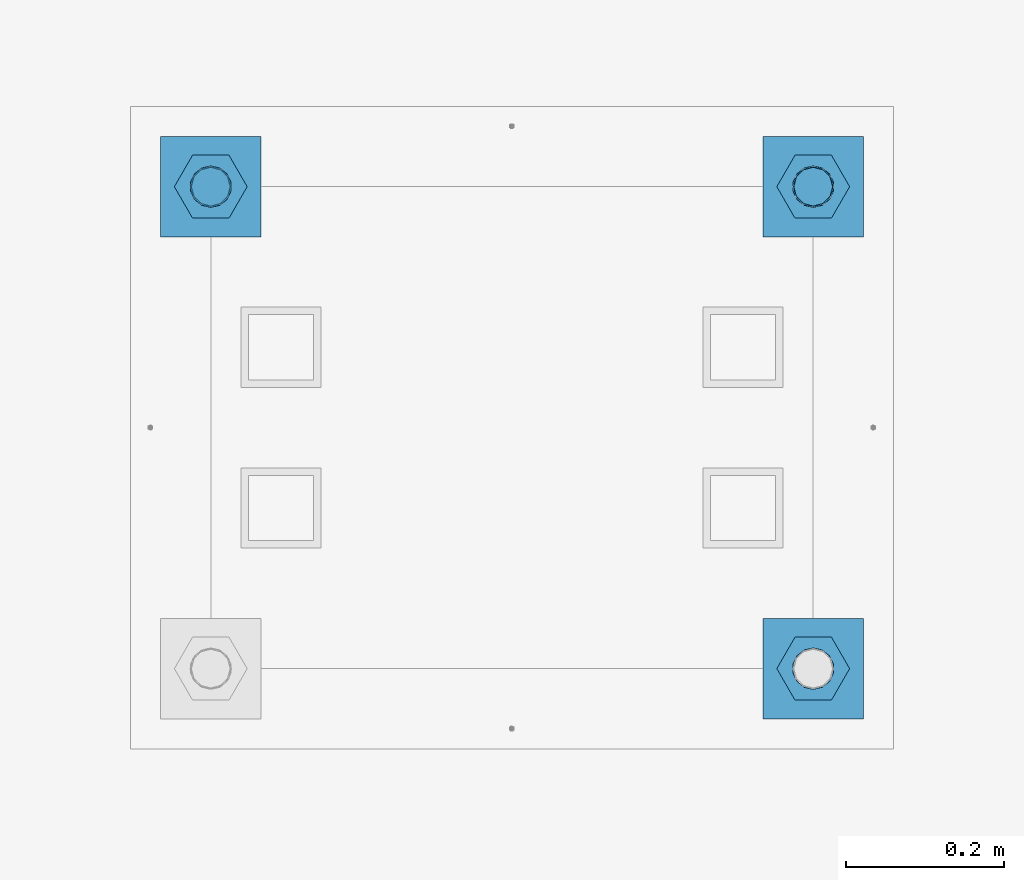
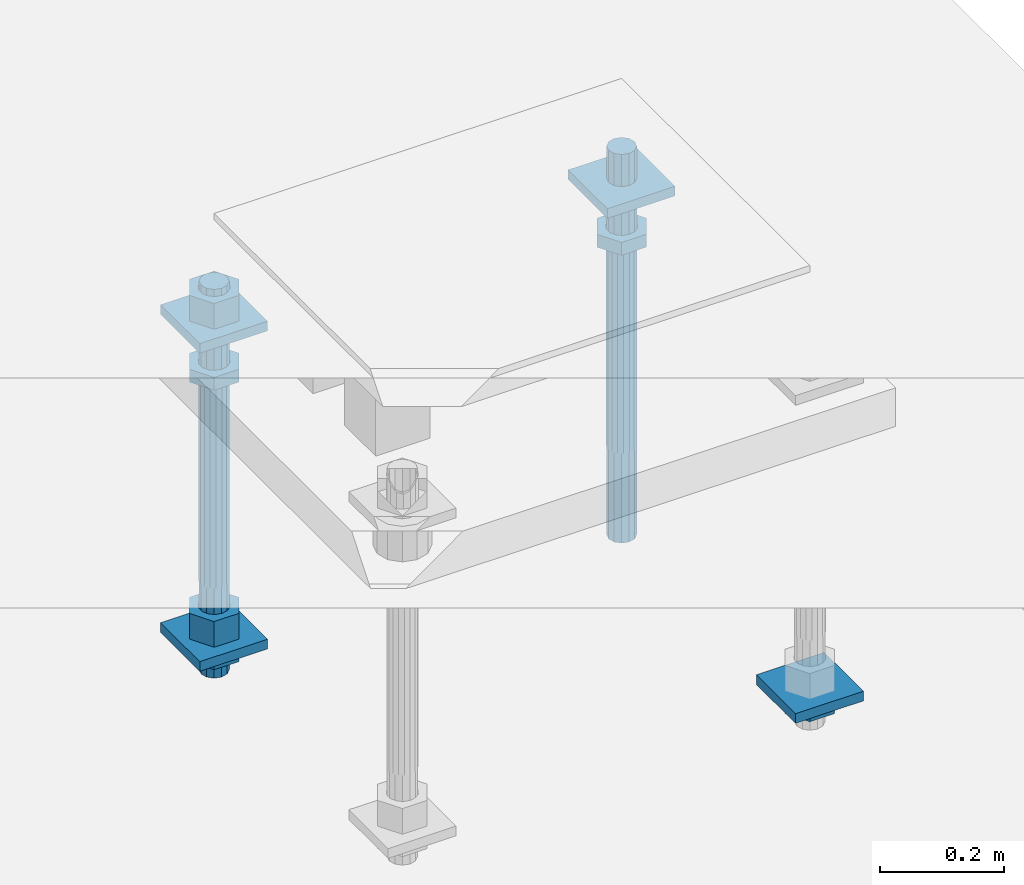
# One storey, part 2651 of 3843: 12 beams, 1 element without a shape of its own.
"""IFC2X3 building model written with IfcOpenShell, lengths in millimetres."""

from ifc_helpers import new_model, si_unit, frame, origin_with_axes, place, context, subcontext, project, spatial, faceted_brep, material, type_object, element, aggregate, save


model = new_model("IFC2X3")

# Units and contexts
model_context = context("Model", 3, precision=1e-05, world=origin_with_axes())
body_context = subcontext(model_context, "Body", "Model", "MODEL_VIEW")
ifc_project = project(units=[si_unit("LENGTHUNIT", "METRE", prefix="MILLI"), si_unit("AREAUNIT", "SQUARE_METRE"), si_unit("VOLUMEUNIT", "CUBIC_METRE"), si_unit("MASSUNIT", "GRAM", prefix="KILO"), si_unit("TIMEUNIT", "SECOND"), si_unit("PLANEANGLEUNIT", "RADIAN"), si_unit("SOLIDANGLEUNIT", "STERADIAN"), si_unit("THERMODYNAMICTEMPERATUREUNIT", "DEGREE_CELSIUS"), si_unit("LUMINOUSINTENSITYUNIT", "LUMEN")], contexts=[model_context])

# Site, building, storey
site_placement = place(None, origin_with_axes())
site = spatial("IfcSite", under=ifc_project, at=site_placement, CompositionType="ELEMENT")
building_placement = place(site_placement, origin_with_axes())
building = spatial("IfcBuilding", under=site, at=building_placement, Name="Undefined", CompositionType="ELEMENT")
storey_placement = place(building_placement, origin_with_axes())
storey = spatial("IfcBuildingStorey", under=building, at=storey_placement, Name="Undefined", CompositionType="ELEMENT", Elevation=0.0)

# Assembly, beams
assembly_placement = place(storey_placement, origin_with_axes())
assembly = element("IfcElementAssembly", 1, at=assembly_placement, inside=storey, Name="TEMPLATE", AssemblyPlace="NOTDEFINED", PredefinedType="RIGID_FRAME")
ifc_material_1 = material(Name="STEEL/A572-50")
beam_type_1 = type_object("IfcBeamType", PredefinedType="NOTDEFINED")
beam_1_placement = place(assembly_placement, frame((118465.6, 10744.2000015259, 29873.575), z_axis=(1.0, 0.0, 0.0), x_axis=(0.0, 1.0, 0.0)))
beam_1 = element("IfcBeam", 2, at=beam_1_placement, type_object=beam_type_1, material=ifc_material_1, Name="WASHER_PLATE", context=body_context, shape_type="Brep", body=[
    faceted_brep([(0.0, 9.52500000000146, -63.5), (0.0, 9.52500000000146, 63.5), (127.0, 9.52500000000146, 63.5), (127.0, 9.52500000000146, -63.5), (0.0, -9.52500000000146, 63.5), (127.0, -9.52500000000146, 63.5), (0.0, -9.52500000000146, -63.5), (127.0, -9.52500000000146, -63.5)], [[[0, 1, 2, 3]], [[1, 4, 5, 2]], [[4, 6, 7, 5]], [[6, 0, 3, 7]], [[5, 7, 3, 2]], [[6, 4, 1, 0]]]),
])
beam_2_placement = place(assembly_placement, frame((119227.6, 10744.2000015259, 29873.575), z_axis=(1.0, 0.0, 0.0), x_axis=(0.0, 1.0, 0.0)))
beam_2 = element("IfcBeam", 3, at=beam_2_placement, type_object=beam_type_1, material=ifc_material_1, Name="WASHER_PLATE", context=body_context, shape_type="Brep", body=[
    faceted_brep([(0.0, 9.52500000000146, -63.5), (0.0, 9.52500000000146, 63.5), (127.0, 9.52500000000146, 63.5), (127.0, 9.52500000000146, -63.5), (0.0, -9.52500000000146, 63.5), (127.0, -9.52500000000146, 63.5), (0.0, -9.52500000000146, -63.5), (127.0, -9.52500000000146, -63.5)], [[[0, 1, 2, 3]], [[1, 4, 5, 2]], [[4, 6, 7, 5]], [[6, 0, 3, 7]], [[5, 7, 3, 2]], [[6, 4, 1, 0]]]),
])
beam_3_placement = place(assembly_placement, frame((119227.6, 10134.6000015259, 29244.925), z_axis=(1.0, 0.0, 0.0), x_axis=(0.0, 1.0, 0.0)))
beam_3 = element("IfcBeam", 4, at=beam_3_placement, type_object=beam_type_1, material=ifc_material_1, Name="WASHER_PLATE", context=body_context, shape_type="Brep", body=[
    faceted_brep([(0.0, 9.52500000000146, -63.5), (0.0, 9.52500000000146, 63.5), (127.0, 9.52500000000146, 63.5), (127.0, 9.52500000000146, -63.5), (0.0, -9.52500000000146, 63.5), (127.0, -9.52500000000146, 63.5), (0.0, -9.52500000000146, -63.5), (127.0, -9.52500000000146, -63.5)], [[[0, 1, 2, 3]], [[1, 4, 5, 2]], [[4, 6, 7, 5]], [[6, 0, 3, 7]], [[5, 7, 3, 2]], [[6, 4, 1, 0]]]),
])
beam_4_placement = place(assembly_placement, frame((118465.6, 10744.2000015259, 29244.925), z_axis=(1.0, 0.0, 0.0), x_axis=(0.0, 1.0, 0.0)))
beam_4 = element("IfcBeam", 5, at=beam_4_placement, type_object=beam_type_1, material=ifc_material_1, Name="WASHER_PLATE", context=body_context, shape_type="Brep", body=[
    faceted_brep([(0.0, 9.52500000000146, -63.5), (0.0, 9.52500000000146, 63.5), (127.0, 9.52500000000146, 63.5), (127.0, 9.52500000000146, -63.5), (0.0, -9.52500000000146, 63.5), (127.0, -9.52500000000146, 63.5), (0.0, -9.52500000000146, -63.5), (127.0, -9.52500000000146, -63.5)], [[[0, 1, 2, 3]], [[1, 4, 5, 2]], [[4, 6, 7, 5]], [[6, 0, 3, 7]], [[5, 7, 3, 2]], [[6, 4, 1, 0]]]),
])
ifc_material_2 = material(Name="STEEL/A36")
beam_type_2 = type_object("IfcBeamType", Name="2_HALF_NUT", PredefinedType="NOTDEFINED")
beam_5_placement = place(assembly_placement, frame((119227.6, 10198.1000015259, 29235.4), z_axis=(0.0, 1.0, 0.0), x_axis=(0.0, 0.0, -1.0)))
beam_5 = element("IfcBeam", 6, at=beam_5_placement, type_object=beam_type_2, material=ifc_material_2, Name="NUT", ObjectType="2_HALF_NUT", context=body_context, shape_type="Brep", body=[
    faceted_brep([(0.0, -46.0369987487793, 0.0), (0.0, -23.0184993743896, -39.869213104248), (25.4000000000015, -23.0184993743896, -39.869213104248), (25.4000000000015, -46.0369987487793, 0.0), (0.0, 23.0184993743896, -39.869213104248), (25.4000000000015, 23.0184993743896, -39.869213104248), (0.0, 46.0369987487793, 0.0), (25.4000000000015, 46.0369987487793, 0.0), (0.0, 23.0184993743896, 39.869213104248), (25.4000000000015, 23.0184993743896, 39.869213104248), (0.0, -23.0184993743896, 39.869213104248), (25.4000000000015, -23.0184993743896, 39.869213104248), (0.0, 0.0, 26.1940002441406), (0.0, 11.3650617044477, 23.5999013092805), (25.4000000000015, 11.3650617044477, 23.5999013092805), (25.4000000000015, 0.0, 26.1940002441406), (0.0, 20.4791109456419, 16.3316083006721), (25.4000000000015, 20.4791109456419, 16.3316083006721), (0.0, 25.5370200498292, 5.82867859874386), (25.4000000000015, 25.5370200498292, 5.82867859874386), (0.0, 25.5370200498292, -5.82867859874386), (25.4000000000015, 25.5370200498292, -5.82867859874386), (0.0, 20.4791109456419, -16.3316083006721), (25.4000000000015, 20.4791109456419, -16.3316083006721), (0.0, 11.3650617044477, -23.5999013092805), (25.4000000000015, 11.3650617044477, -23.5999013092805), (0.0, 0.0, -26.1940002441406), (25.4000000000015, 0.0, -26.1940002441406), (0.0, -11.3650617044477, -23.5999013092805), (25.4000000000015, -11.3650617044477, -23.5999013092805), (0.0, -20.4791109456419, -16.3316083006721), (25.4000000000015, -20.4791109456419, -16.3316083006721), (0.0, -25.5370200498292, -5.82867859874386), (25.4000000000015, -25.5370200498292, -5.82867859874386), (0.0, -25.5370200498292, 5.82867859874386), (25.4000000000015, -25.5370200498292, 5.82867859874386), (0.0, -20.4791109456419, 16.3316083006721), (25.4000000000015, -20.4791109456419, 16.3316083006721), (0.0, -11.3650617044477, 23.5999013092805), (25.4000000000015, -11.3650617044477, 23.5999013092805)], [[[0, 1, 2, 3]], [[1, 4, 5, 2]], [[4, 6, 7, 5]], [[6, 8, 9, 7]], [[8, 10, 11, 9]], [[10, 0, 3, 11]], [[12, 13, 14, 15]], [[13, 16, 17, 14]], [[16, 18, 19, 17]], [[18, 20, 21, 19]], [[20, 22, 23, 21]], [[22, 24, 25, 23]], [[24, 26, 27, 25]], [[26, 28, 29, 27]], [[28, 30, 31, 29]], [[30, 32, 33, 31]], [[32, 34, 35, 33]], [[34, 36, 37, 35]], [[36, 38, 39, 37]], [[38, 12, 15, 39]], [[5, 7, 9, 11, 3, 2], [17, 19, 21, 23, 25, 27, 29, 31, 33, 35, 37, 39, 15, 14]], [[10, 8, 6, 4, 1, 0], [38, 36, 34, 32, 30, 28, 26, 24, 22, 20, 18, 16, 13, 12]]]),
])
beam_6_placement = place(assembly_placement, frame((118465.6, 10807.7000015259, 29787.85), z_axis=(0.0, 1.0, 0.0), x_axis=(0.0, 0.0, -1.0)))
beam_6 = element("IfcBeam", 7, at=beam_6_placement, type_object=beam_type_2, material=ifc_material_2, Name="NUT", ObjectType="2_HALF_NUT", context=body_context, shape_type="Brep", body=[
    faceted_brep([(0.0, -46.0369987487793, 0.0), (0.0, -23.0184993743896, -39.869213104248), (25.4000000000015, -23.0184993743896, -39.869213104248), (25.4000000000015, -46.0369987487793, 0.0), (0.0, 23.0184993743896, -39.869213104248), (25.4000000000015, 23.0184993743896, -39.869213104248), (0.0, 46.0369987487793, 0.0), (25.4000000000015, 46.0369987487793, 0.0), (0.0, 23.0184993743896, 39.869213104248), (25.4000000000015, 23.0184993743896, 39.869213104248), (0.0, -23.0184993743896, 39.869213104248), (25.4000000000015, -23.0184993743896, 39.869213104248), (0.0, 0.0, 26.1940002441406), (0.0, 11.3650617044477, 23.5999013092805), (25.4000000000015, 11.3650617044477, 23.5999013092805), (25.4000000000015, 0.0, 26.1940002441406), (0.0, 20.4791109456419, 16.3316083006721), (25.4000000000015, 20.4791109456419, 16.3316083006721), (0.0, 25.5370200498292, 5.82867859874386), (25.4000000000015, 25.5370200498292, 5.82867859874386), (0.0, 25.5370200498292, -5.82867859874386), (25.4000000000015, 25.5370200498292, -5.82867859874386), (0.0, 20.4791109456419, -16.3316083006721), (25.4000000000015, 20.4791109456419, -16.3316083006721), (0.0, 11.3650617044477, -23.5999013092805), (25.4000000000015, 11.3650617044477, -23.5999013092805), (0.0, 0.0, -26.1940002441406), (25.4000000000015, 0.0, -26.1940002441406), (0.0, -11.3650617044477, -23.5999013092805), (25.4000000000015, -11.3650617044477, -23.5999013092805), (0.0, -20.4791109456419, -16.3316083006721), (25.4000000000015, -20.4791109456419, -16.3316083006721), (0.0, -25.5370200498292, -5.82867859874386), (25.4000000000015, -25.5370200498292, -5.82867859874386), (0.0, -25.5370200498292, 5.82867859874386), (25.4000000000015, -25.5370200498292, 5.82867859874386), (0.0, -20.4791109456419, 16.3316083006721), (25.4000000000015, -20.4791109456419, 16.3316083006721), (0.0, -11.3650617044477, 23.5999013092805), (25.4000000000015, -11.3650617044477, 23.5999013092805)], [[[0, 1, 2, 3]], [[1, 4, 5, 2]], [[4, 6, 7, 5]], [[6, 8, 9, 7]], [[8, 10, 11, 9]], [[10, 0, 3, 11]], [[12, 13, 14, 15]], [[13, 16, 17, 14]], [[16, 18, 19, 17]], [[18, 20, 21, 19]], [[20, 22, 23, 21]], [[22, 24, 25, 23]], [[24, 26, 27, 25]], [[26, 28, 29, 27]], [[28, 30, 31, 29]], [[30, 32, 33, 31]], [[32, 34, 35, 33]], [[34, 36, 37, 35]], [[36, 38, 39, 37]], [[38, 12, 15, 39]], [[5, 7, 9, 11, 3, 2], [17, 19, 21, 23, 25, 27, 29, 31, 33, 35, 37, 39, 15, 14]], [[10, 8, 6, 4, 1, 0], [38, 36, 34, 32, 30, 28, 26, 24, 22, 20, 18, 16, 13, 12]]]),
])
beam_7_placement = place(assembly_placement, frame((118465.6, 10807.7000015259, 29235.4), z_axis=(0.0, 1.0, 0.0), x_axis=(0.0, 0.0, -1.0)))
beam_7 = element("IfcBeam", 8, at=beam_7_placement, type_object=beam_type_2, material=ifc_material_2, Name="NUT", ObjectType="2_HALF_NUT", context=body_context, shape_type="Brep", body=[
    faceted_brep([(0.0, -46.0369987487793, 0.0), (0.0, -23.0184993743896, -39.869213104248), (25.4000000000015, -23.0184993743896, -39.869213104248), (25.4000000000015, -46.0369987487793, 0.0), (0.0, 23.0184993743896, -39.869213104248), (25.4000000000015, 23.0184993743896, -39.869213104248), (0.0, 46.0369987487793, 0.0), (25.4000000000015, 46.0369987487793, 0.0), (0.0, 23.0184993743896, 39.869213104248), (25.4000000000015, 23.0184993743896, 39.869213104248), (0.0, -23.0184993743896, 39.869213104248), (25.4000000000015, -23.0184993743896, 39.869213104248), (0.0, 0.0, 26.1940002441406), (0.0, 11.3650617044477, 23.5999013092805), (25.4000000000015, 11.3650617044477, 23.5999013092805), (25.4000000000015, 0.0, 26.1940002441406), (0.0, 20.4791109456419, 16.3316083006721), (25.4000000000015, 20.4791109456419, 16.3316083006721), (0.0, 25.5370200498292, 5.82867859874386), (25.4000000000015, 25.5370200498292, 5.82867859874386), (0.0, 25.5370200498292, -5.82867859874386), (25.4000000000015, 25.5370200498292, -5.82867859874386), (0.0, 20.4791109456419, -16.3316083006721), (25.4000000000015, 20.4791109456419, -16.3316083006721), (0.0, 11.3650617044477, -23.5999013092805), (25.4000000000015, 11.3650617044477, -23.5999013092805), (0.0, 0.0, -26.1940002441406), (25.4000000000015, 0.0, -26.1940002441406), (0.0, -11.3650617044477, -23.5999013092805), (25.4000000000015, -11.3650617044477, -23.5999013092805), (0.0, -20.4791109456419, -16.3316083006721), (25.4000000000015, -20.4791109456419, -16.3316083006721), (0.0, -25.5370200498292, -5.82867859874386), (25.4000000000015, -25.5370200498292, -5.82867859874386), (0.0, -25.5370200498292, 5.82867859874386), (25.4000000000015, -25.5370200498292, 5.82867859874386), (0.0, -20.4791109456419, 16.3316083006721), (25.4000000000015, -20.4791109456419, 16.3316083006721), (0.0, -11.3650617044477, 23.5999013092805), (25.4000000000015, -11.3650617044477, 23.5999013092805)], [[[0, 1, 2, 3]], [[1, 4, 5, 2]], [[4, 6, 7, 5]], [[6, 8, 9, 7]], [[8, 10, 11, 9]], [[10, 0, 3, 11]], [[12, 13, 14, 15]], [[13, 16, 17, 14]], [[16, 18, 19, 17]], [[18, 20, 21, 19]], [[20, 22, 23, 21]], [[22, 24, 25, 23]], [[24, 26, 27, 25]], [[26, 28, 29, 27]], [[28, 30, 31, 29]], [[30, 32, 33, 31]], [[32, 34, 35, 33]], [[34, 36, 37, 35]], [[36, 38, 39, 37]], [[38, 12, 15, 39]], [[5, 7, 9, 11, 3, 2], [17, 19, 21, 23, 25, 27, 29, 31, 33, 35, 37, 39, 15, 14]], [[10, 8, 6, 4, 1, 0], [38, 36, 34, 32, 30, 28, 26, 24, 22, 20, 18, 16, 13, 12]]]),
])
beam_8_placement = place(assembly_placement, frame((119227.6, 10807.7000015259, 29787.85), z_axis=(0.0, 1.0, 0.0), x_axis=(0.0, 0.0, -1.0)))
beam_8 = element("IfcBeam", 9, at=beam_8_placement, type_object=beam_type_2, material=ifc_material_2, Name="NUT", ObjectType="2_HALF_NUT", context=body_context, shape_type="Brep", body=[
    faceted_brep([(0.0, -46.0369987487793, 0.0), (0.0, -23.0184993743896, -39.869213104248), (25.4000000000015, -23.0184993743896, -39.869213104248), (25.4000000000015, -46.0369987487793, 0.0), (0.0, 23.0184993743896, -39.869213104248), (25.4000000000015, 23.0184993743896, -39.869213104248), (0.0, 46.0369987487793, 0.0), (25.4000000000015, 46.0369987487793, 0.0), (0.0, 23.0184993743896, 39.869213104248), (25.4000000000015, 23.0184993743896, 39.869213104248), (0.0, -23.0184993743896, 39.869213104248), (25.4000000000015, -23.0184993743896, 39.869213104248), (0.0, 0.0, 26.1940002441406), (0.0, 11.3650617044477, 23.5999013092805), (25.4000000000015, 11.3650617044477, 23.5999013092805), (25.4000000000015, 0.0, 26.1940002441406), (0.0, 20.4791109456419, 16.3316083006721), (25.4000000000015, 20.4791109456419, 16.3316083006721), (0.0, 25.5370200498292, 5.82867859874386), (25.4000000000015, 25.5370200498292, 5.82867859874386), (0.0, 25.5370200498292, -5.82867859874386), (25.4000000000015, 25.5370200498292, -5.82867859874386), (0.0, 20.4791109456419, -16.3316083006721), (25.4000000000015, 20.4791109456419, -16.3316083006721), (0.0, 11.3650617044477, -23.5999013092805), (25.4000000000015, 11.3650617044477, -23.5999013092805), (0.0, 0.0, -26.1940002441406), (25.4000000000015, 0.0, -26.1940002441406), (0.0, -11.3650617044477, -23.5999013092805), (25.4000000000015, -11.3650617044477, -23.5999013092805), (0.0, -20.4791109456419, -16.3316083006721), (25.4000000000015, -20.4791109456419, -16.3316083006721), (0.0, -25.5370200498292, -5.82867859874386), (25.4000000000015, -25.5370200498292, -5.82867859874386), (0.0, -25.5370200498292, 5.82867859874386), (25.4000000000015, -25.5370200498292, 5.82867859874386), (0.0, -20.4791109456419, 16.3316083006721), (25.4000000000015, -20.4791109456419, 16.3316083006721), (0.0, -11.3650617044477, 23.5999013092805), (25.4000000000015, -11.3650617044477, 23.5999013092805)], [[[0, 1, 2, 3]], [[1, 4, 5, 2]], [[4, 6, 7, 5]], [[6, 8, 9, 7]], [[8, 10, 11, 9]], [[10, 0, 3, 11]], [[12, 13, 14, 15]], [[13, 16, 17, 14]], [[16, 18, 19, 17]], [[18, 20, 21, 19]], [[20, 22, 23, 21]], [[22, 24, 25, 23]], [[24, 26, 27, 25]], [[26, 28, 29, 27]], [[28, 30, 31, 29]], [[30, 32, 33, 31]], [[32, 34, 35, 33]], [[34, 36, 37, 35]], [[36, 38, 39, 37]], [[38, 12, 15, 39]], [[5, 7, 9, 11, 3, 2], [17, 19, 21, 23, 25, 27, 29, 31, 33, 35, 37, 39, 15, 14]], [[10, 8, 6, 4, 1, 0], [38, 36, 34, 32, 30, 28, 26, 24, 22, 20, 18, 16, 13, 12]]]),
])
beam_type_3 = type_object("IfcBeamType", Name="2_HEAVY_HEX_NUT", PredefinedType="NOTDEFINED")
beam_9_placement = place(assembly_placement, frame((118465.6, 10807.7000015259, 29933.9), z_axis=(0.0, 1.0, 0.0), x_axis=(0.0, 0.0, -1.0)))
beam_9 = element("IfcBeam", 10, at=beam_9_placement, type_object=beam_type_3, material=ifc_material_2, Name="NUT", ObjectType="2_HEAVY_HEX_NUT", context=body_context, shape_type="Brep", body=[
    faceted_brep([(0.0, -46.0369987487793, 0.0), (0.0, -23.0184993743896, -39.869213104248), (50.7999999999993, -23.0184993743896, -39.869213104248), (50.7999999999993, -46.0369987487793, 0.0), (0.0, 23.0184993743896, -39.869213104248), (50.7999999999993, 23.0184993743896, -39.869213104248), (0.0, 46.0369987487793, 0.0), (50.7999999999993, 46.0369987487793, 0.0), (0.0, 23.0184993743896, 39.869213104248), (50.7999999999993, 23.0184993743896, 39.869213104248), (0.0, -23.0184993743896, 39.869213104248), (50.7999999999993, -23.0184993743896, 39.869213104248), (0.0, 0.0, 26.1940002441406), (0.0, 11.3650617044477, 23.5999013092805), (50.7999999999993, 11.3650617044477, 23.5999013092805), (50.7999999999993, 0.0, 26.1940002441406), (0.0, 20.4791109456419, 16.3316083006721), (50.7999999999993, 20.4791109456419, 16.3316083006721), (0.0, 25.5370200498292, 5.82867859874386), (50.7999999999993, 25.5370200498292, 5.82867859874386), (0.0, 25.5370200498292, -5.82867859874386), (50.7999999999993, 25.5370200498292, -5.82867859874386), (0.0, 20.4791109456419, -16.3316083006721), (50.7999999999993, 20.4791109456419, -16.3316083006721), (0.0, 11.3650617044477, -23.5999013092805), (50.7999999999993, 11.3650617044477, -23.5999013092805), (0.0, 0.0, -26.1940002441406), (50.7999999999993, 0.0, -26.1940002441406), (0.0, -11.3650617044477, -23.5999013092805), (50.7999999999993, -11.3650617044477, -23.5999013092805), (0.0, -20.4791109456419, -16.3316083006721), (50.7999999999993, -20.4791109456419, -16.3316083006721), (0.0, -25.5370200498292, -5.82867859874386), (50.7999999999993, -25.5370200498292, -5.82867859874386), (0.0, -25.5370200498292, 5.82867859874386), (50.7999999999993, -25.5370200498292, 5.82867859874386), (0.0, -20.4791109456419, 16.3316083006721), (50.7999999999993, -20.4791109456419, 16.3316083006721), (0.0, -11.3650617044477, 23.5999013092805), (50.7999999999993, -11.3650617044477, 23.5999013092805)], [[[0, 1, 2, 3]], [[1, 4, 5, 2]], [[4, 6, 7, 5]], [[6, 8, 9, 7]], [[8, 10, 11, 9]], [[10, 0, 3, 11]], [[12, 13, 14, 15]], [[13, 16, 17, 14]], [[16, 18, 19, 17]], [[18, 20, 21, 19]], [[20, 22, 23, 21]], [[22, 24, 25, 23]], [[24, 26, 27, 25]], [[26, 28, 29, 27]], [[28, 30, 31, 29]], [[30, 32, 33, 31]], [[32, 34, 35, 33]], [[34, 36, 37, 35]], [[36, 38, 39, 37]], [[38, 12, 15, 39]], [[5, 7, 9, 11, 3, 2], [17, 19, 21, 23, 25, 27, 29, 31, 33, 35, 37, 39, 15, 14]], [[10, 8, 6, 4, 1, 0], [38, 36, 34, 32, 30, 28, 26, 24, 22, 20, 18, 16, 13, 12]]]),
])
beam_10_placement = place(assembly_placement, frame((118465.6, 10807.7000015259, 29305.25), z_axis=(0.0, 1.0, 0.0), x_axis=(0.0, 0.0, -1.0)))
beam_10 = element("IfcBeam", 11, at=beam_10_placement, type_object=beam_type_3, material=ifc_material_2, Name="NUT", ObjectType="2_HEAVY_HEX_NUT", context=body_context, shape_type="Brep", body=[
    faceted_brep([(0.0, -46.0369987487793, 0.0), (0.0, -23.0184993743896, -39.869213104248), (50.7999999999993, -23.0184993743896, -39.869213104248), (50.7999999999993, -46.0369987487793, 0.0), (0.0, 23.0184993743896, -39.869213104248), (50.7999999999993, 23.0184993743896, -39.869213104248), (0.0, 46.0369987487793, 0.0), (50.7999999999993, 46.0369987487793, 0.0), (0.0, 23.0184993743896, 39.869213104248), (50.7999999999993, 23.0184993743896, 39.869213104248), (0.0, -23.0184993743896, 39.869213104248), (50.7999999999993, -23.0184993743896, 39.869213104248), (0.0, 0.0, 26.1940002441406), (0.0, 11.3650617044477, 23.5999013092805), (50.7999999999993, 11.3650617044477, 23.5999013092805), (50.7999999999993, 0.0, 26.1940002441406), (0.0, 20.4791109456419, 16.3316083006721), (50.7999999999993, 20.4791109456419, 16.3316083006721), (0.0, 25.5370200498292, 5.82867859874386), (50.7999999999993, 25.5370200498292, 5.82867859874386), (0.0, 25.5370200498292, -5.82867859874386), (50.7999999999993, 25.5370200498292, -5.82867859874386), (0.0, 20.4791109456419, -16.3316083006721), (50.7999999999993, 20.4791109456419, -16.3316083006721), (0.0, 11.3650617044477, -23.5999013092805), (50.7999999999993, 11.3650617044477, -23.5999013092805), (0.0, 0.0, -26.1940002441406), (50.7999999999993, 0.0, -26.1940002441406), (0.0, -11.3650617044477, -23.5999013092805), (50.7999999999993, -11.3650617044477, -23.5999013092805), (0.0, -20.4791109456419, -16.3316083006721), (50.7999999999993, -20.4791109456419, -16.3316083006721), (0.0, -25.5370200498292, -5.82867859874386), (50.7999999999993, -25.5370200498292, -5.82867859874386), (0.0, -25.5370200498292, 5.82867859874386), (50.7999999999993, -25.5370200498292, 5.82867859874386), (0.0, -20.4791109456419, 16.3316083006721), (50.7999999999993, -20.4791109456419, 16.3316083006721), (0.0, -11.3650617044477, 23.5999013092805), (50.7999999999993, -11.3650617044477, 23.5999013092805)], [[[0, 1, 2, 3]], [[1, 4, 5, 2]], [[4, 6, 7, 5]], [[6, 8, 9, 7]], [[8, 10, 11, 9]], [[10, 0, 3, 11]], [[12, 13, 14, 15]], [[13, 16, 17, 14]], [[16, 18, 19, 17]], [[18, 20, 21, 19]], [[20, 22, 23, 21]], [[22, 24, 25, 23]], [[24, 26, 27, 25]], [[26, 28, 29, 27]], [[28, 30, 31, 29]], [[30, 32, 33, 31]], [[32, 34, 35, 33]], [[34, 36, 37, 35]], [[36, 38, 39, 37]], [[38, 12, 15, 39]], [[5, 7, 9, 11, 3, 2], [17, 19, 21, 23, 25, 27, 29, 31, 33, 35, 37, 39, 15, 14]], [[10, 8, 6, 4, 1, 0], [38, 36, 34, 32, 30, 28, 26, 24, 22, 20, 18, 16, 13, 12]]]),
])
ifc_material_3 = material()
beam_type_4 = type_object("IfcBeamType", PredefinedType="NOTDEFINED")
beam_11_placement = place(assembly_placement, frame((118465.600001526, 10807.7, 29762.45), z_axis=(1.0, 0.0, 0.0), x_axis=(0.0, 0.0, -1.0)))
beam_11 = element("IfcBeam", 12, at=beam_11_placement, type_object=beam_type_4, material=ifc_material_3, Name="ANCHOR_ROD", context=body_context, shape_type="Brep", body=[
    faceted_brep([(0.0, -23.4665401257807, -9.72015918207035), (0.0, -17.9605122421344, -17.9605122421417), (406.399999999998, -17.9605122421344, -17.9605122421417), (406.399999999998, -23.4665401257807, -9.72015918207035), (0.0, -9.72015918207762, -23.466540125788), (406.399999999998, -9.72015918207762, -23.466540125788), (0.0, 0.0, -25.4000000000015), (406.399999999998, 0.0, -25.4000000000015), (0.0, 9.72015918207762, -23.466540125788), (406.399999999998, 9.72015918207762, -23.466540125788), (0.0, 17.9605122421344, -17.9605122421417), (406.399999999998, 17.9605122421344, -17.9605122421417), (0.0, 23.4665401257807, -9.72015918207035), (406.399999999998, 23.4665401257807, -9.72015918207035), (0.0, 25.3999996185303, 0.0), (406.399999999998, 25.3999999999942, 0.0), (0.0, 23.4665401257807, 9.72015918207035), (406.399999999998, 23.4665401257807, 9.72015918207035), (0.0, 17.9605122421344, 17.9605122421417), (406.399999999998, 17.9605122421344, 17.9605122421417), (0.0, 9.72015918207762, 23.466540125788), (406.399999999998, 9.72015918207762, 23.466540125788), (0.0, 0.0, 25.4000000000015), (406.399999999998, 0.0, 25.4000000000015), (0.0, -9.72015918207762, 23.466540125788), (406.399999999998, -9.72015918207762, 23.466540125788), (0.0, -17.9605122421344, 17.9605122421417), (406.399999999998, -17.9605122421344, 17.9605122421417), (0.0, -23.4665401257807, 9.72015918207035), (406.399999999998, -23.4665401257807, 9.72015918207035), (0.0, -25.3999996185303, 0.0), (406.399999999998, -25.3999999999942, 0.0), (584.200000000001, -12.2499999999854, -21.2176223927163), (584.200000000001, 1.45519152283669e-11, -24.5), (584.200000000001, 12.2500000000146, -21.2176223927163), (584.200000000001, 21.2176223927381, -12.25), (584.200000000001, 24.5000000000146, 0.0), (584.200000000001, 21.2176223927381, 12.25), (584.200000000001, 12.2500000000146, 21.2176223927163), (584.200000000001, 1.45519152283669e-11, 24.5), (584.200000000001, -12.2499999999854, 21.2176223927163), (584.200000000001, -21.217622392709, 12.25), (584.200000000001, -24.4999999999854, 0.0), (584.200000000001, -21.217622392709, -12.25), (406.399999999998, -24.4999999999854, 0.0), (406.399999999998, -21.217622392709, -12.25), (406.399999999998, -12.2499999999854, -21.2176223927163), (406.399999999998, 1.45519152283669e-11, -24.5), (406.399999999998, 12.2500000000146, -21.2176223927163), (406.399999999998, 21.2176223927381, -12.25), (406.399999999998, 24.5000000000146, 0.0), (406.399999999998, 21.2176223927381, 12.25), (406.399999999998, 12.2500000000146, 21.2176223927163), (406.399999999998, 1.45519152283669e-11, 24.5), (406.399999999998, -12.2499999999854, 21.2176223927163), (406.399999999998, -21.217622392709, 12.25), (0.0, 12.2500000000146, 21.2176223927163), (0.0, 1.45519152283669e-11, 24.5), (0.0, -12.2499999999854, 21.2176223927163), (0.0, -21.217622392709, 12.25), (0.0, -24.4999999999854, 0.0), (0.0, -21.217622392709, -12.25), (0.0, -12.2499999999854, -21.2176223927163), (0.0, 1.45519152283669e-11, -24.5), (0.0, 12.2500000000146, -21.2176223927163), (0.0, 21.2176223927381, -12.25), (0.0, 24.5000000000146, 0.0), (0.0, 21.2176223927381, 12.25), (-184.150000000001, -21.217622392709, 12.25), (-184.150000000001, -12.2499999999854, 21.2176223927163), (-184.150000000001, 1.45519152283669e-11, 24.5), (-184.150000000001, 12.2500000000146, 21.2176223927163), (-184.150000000001, 21.2176223927381, 12.25), (-184.150000000001, 24.5000000000146, 0.0), (-184.150000000001, 21.2176223927381, -12.25), (-184.150000000001, 12.2500000000146, -21.2176223927163), (-184.150000000001, 1.45519152283669e-11, -24.5), (-184.150000000001, -12.2499999999854, -21.2176223927163), (-184.150000000001, -21.217622392709, -12.25), (-184.150000000001, -24.4999999999854, 0.0)], [[[0, 1, 2, 3]], [[1, 4, 5, 2]], [[4, 6, 7, 5]], [[6, 8, 9, 7]], [[8, 10, 11, 9]], [[10, 12, 13, 11]], [[12, 14, 15, 13]], [[14, 16, 17, 15]], [[16, 18, 19, 17]], [[18, 20, 21, 19]], [[20, 22, 23, 21]], [[22, 24, 25, 23]], [[24, 26, 27, 25]], [[26, 28, 29, 27]], [[28, 30, 31, 29]], [[32, 33, 34, 35, 36, 37, 38, 39, 40, 41, 42, 43]], [[43, 42, 44, 45]], [[32, 43, 45, 46]], [[33, 32, 46, 47]], [[34, 33, 47, 48]], [[35, 34, 48, 49]], [[36, 35, 49, 50]], [[37, 36, 50, 51]], [[38, 37, 51, 52]], [[39, 38, 52, 53]], [[40, 39, 53, 54]], [[41, 40, 54, 55]], [[42, 41, 55, 44]], [[2, 5, 7, 9, 11, 13, 15, 17, 19, 21, 23, 25, 27, 29, 31, 3], [54, 53, 52, 51, 50, 49, 48, 47, 46, 45, 44, 55]], [[30, 0, 3, 31]], [[28, 26, 24, 22, 20, 18, 16, 14, 12, 10, 8, 6, 4, 1, 0, 30], [56, 57, 58, 59, 60, 61, 62, 63, 64, 65, 66, 67]], [[68, 69, 70, 71, 72, 73, 74, 75, 76, 77, 78, 79]], [[71, 70, 57, 56]], [[72, 71, 56, 67]], [[73, 72, 67, 66]], [[74, 73, 66, 65]], [[75, 74, 65, 64]], [[76, 75, 64, 63]], [[77, 76, 63, 62]], [[78, 77, 62, 61]], [[79, 78, 61, 60]], [[68, 79, 60, 59]], [[69, 68, 59, 58]], [[70, 69, 58, 57]]]),
])
beam_12_placement = place(assembly_placement, frame((119227.600001526, 10807.7, 29762.45), z_axis=(1.0, 0.0, 0.0), x_axis=(0.0, 0.0, -1.0)))
beam_12 = element("IfcBeam", 13, at=beam_12_placement, type_object=beam_type_4, material=ifc_material_3, Name="ANCHOR_ROD", context=body_context, shape_type="Brep", body=[
    faceted_brep([(0.0, -23.4665401257807, -9.72015918207035), (0.0, -17.9605122421344, -17.9605122421417), (406.399999999998, -17.9605122421344, -17.9605122421417), (406.399999999998, -23.4665401257807, -9.72015918207035), (0.0, -9.72015918207762, -23.466540125788), (406.399999999998, -9.72015918207762, -23.466540125788), (0.0, 0.0, -25.4000000000015), (406.399999999998, 0.0, -25.4000000000015), (0.0, 9.72015918207762, -23.466540125788), (406.399999999998, 9.72015918207762, -23.466540125788), (0.0, 17.9605122421344, -17.9605122421417), (406.399999999998, 17.9605122421344, -17.9605122421417), (0.0, 23.4665401257807, -9.72015918207035), (406.399999999998, 23.4665401257807, -9.72015918207035), (0.0, 25.3999996185303, 0.0), (406.399999999998, 25.3999999999942, 0.0), (0.0, 23.4665401257807, 9.72015918207035), (406.399999999998, 23.4665401257807, 9.72015918207035), (0.0, 17.9605122421344, 17.9605122421417), (406.399999999998, 17.9605122421344, 17.9605122421417), (0.0, 9.72015918207762, 23.466540125788), (406.399999999998, 9.72015918207762, 23.466540125788), (0.0, 0.0, 25.4000000000015), (406.399999999998, 0.0, 25.4000000000015), (0.0, -9.72015918207762, 23.466540125788), (406.399999999998, -9.72015918207762, 23.466540125788), (0.0, -17.9605122421344, 17.9605122421417), (406.399999999998, -17.9605122421344, 17.9605122421417), (0.0, -23.4665401257807, 9.72015918207035), (406.399999999998, -23.4665401257807, 9.72015918207035), (0.0, -25.3999996185303, 0.0), (406.399999999998, -25.3999999999942, 0.0), (584.200000000001, -12.2499999999854, -21.2176223927163), (584.200000000001, 1.45519152283669e-11, -24.5), (584.200000000001, 12.2500000000146, -21.2176223927163), (584.200000000001, 21.2176223927381, -12.25), (584.200000000001, 24.5000000000146, 0.0), (584.200000000001, 21.2176223927381, 12.25), (584.200000000001, 12.2500000000146, 21.2176223927163), (584.200000000001, 1.45519152283669e-11, 24.5), (584.200000000001, -12.2499999999854, 21.2176223927163), (584.200000000001, -21.217622392709, 12.25), (584.200000000001, -24.4999999999854, 0.0), (584.200000000001, -21.217622392709, -12.25), (406.399999999998, -24.4999999999854, 0.0), (406.399999999998, -21.217622392709, -12.25), (406.399999999998, -12.2499999999854, -21.2176223927163), (406.399999999998, 1.45519152283669e-11, -24.5), (406.399999999998, 12.2500000000146, -21.2176223927163), (406.399999999998, 21.2176223927381, -12.25), (406.399999999998, 24.5000000000146, 0.0), (406.399999999998, 21.2176223927381, 12.25), (406.399999999998, 12.2500000000146, 21.2176223927163), (406.399999999998, 1.45519152283669e-11, 24.5), (406.399999999998, -12.2499999999854, 21.2176223927163), (406.399999999998, -21.217622392709, 12.25), (0.0, 12.2500000000146, 21.2176223927163), (0.0, 1.45519152283669e-11, 24.5), (0.0, -12.2499999999854, 21.2176223927163), (0.0, -21.217622392709, 12.25), (0.0, -24.4999999999854, 0.0), (0.0, -21.217622392709, -12.25), (0.0, -12.2499999999854, -21.2176223927163), (0.0, 1.45519152283669e-11, -24.5), (0.0, 12.2500000000146, -21.2176223927163), (0.0, 21.2176223927381, -12.25), (0.0, 24.5000000000146, 0.0), (0.0, 21.2176223927381, 12.25), (-184.150000000001, -21.217622392709, 12.25), (-184.150000000001, -12.2499999999854, 21.2176223927163), (-184.150000000001, 1.45519152283669e-11, 24.5), (-184.150000000001, 12.2500000000146, 21.2176223927163), (-184.150000000001, 21.2176223927381, 12.25), (-184.150000000001, 24.5000000000146, 0.0), (-184.150000000001, 21.2176223927381, -12.25), (-184.150000000001, 12.2500000000146, -21.2176223927163), (-184.150000000001, 1.45519152283669e-11, -24.5), (-184.150000000001, -12.2499999999854, -21.2176223927163), (-184.150000000001, -21.217622392709, -12.25), (-184.150000000001, -24.4999999999854, 0.0)], [[[0, 1, 2, 3]], [[1, 4, 5, 2]], [[4, 6, 7, 5]], [[6, 8, 9, 7]], [[8, 10, 11, 9]], [[10, 12, 13, 11]], [[12, 14, 15, 13]], [[14, 16, 17, 15]], [[16, 18, 19, 17]], [[18, 20, 21, 19]], [[20, 22, 23, 21]], [[22, 24, 25, 23]], [[24, 26, 27, 25]], [[26, 28, 29, 27]], [[28, 30, 31, 29]], [[32, 33, 34, 35, 36, 37, 38, 39, 40, 41, 42, 43]], [[43, 42, 44, 45]], [[32, 43, 45, 46]], [[33, 32, 46, 47]], [[34, 33, 47, 48]], [[35, 34, 48, 49]], [[36, 35, 49, 50]], [[37, 36, 50, 51]], [[38, 37, 51, 52]], [[39, 38, 52, 53]], [[40, 39, 53, 54]], [[41, 40, 54, 55]], [[42, 41, 55, 44]], [[2, 5, 7, 9, 11, 13, 15, 17, 19, 21, 23, 25, 27, 29, 31, 3], [54, 53, 52, 51, 50, 49, 48, 47, 46, 45, 44, 55]], [[30, 0, 3, 31]], [[28, 26, 24, 22, 20, 18, 16, 14, 12, 10, 8, 6, 4, 1, 0, 30], [56, 57, 58, 59, 60, 61, 62, 63, 64, 65, 66, 67]], [[68, 69, 70, 71, 72, 73, 74, 75, 76, 77, 78, 79]], [[71, 70, 57, 56]], [[72, 71, 56, 67]], [[73, 72, 67, 66]], [[74, 73, 66, 65]], [[75, 74, 65, 64]], [[76, 75, 64, 63]], [[77, 76, 63, 62]], [[78, 77, 62, 61]], [[79, 78, 61, 60]], [[68, 79, 60, 59]], [[69, 68, 59, 58]], [[70, 69, 58, 57]]]),
])
aggregate(assembly, [beam_11, beam_12, beam_1, beam_2, beam_5, beam_3, beam_6, beam_9, beam_10, beam_7, beam_4, beam_8])

save(model, "model.ifc")
